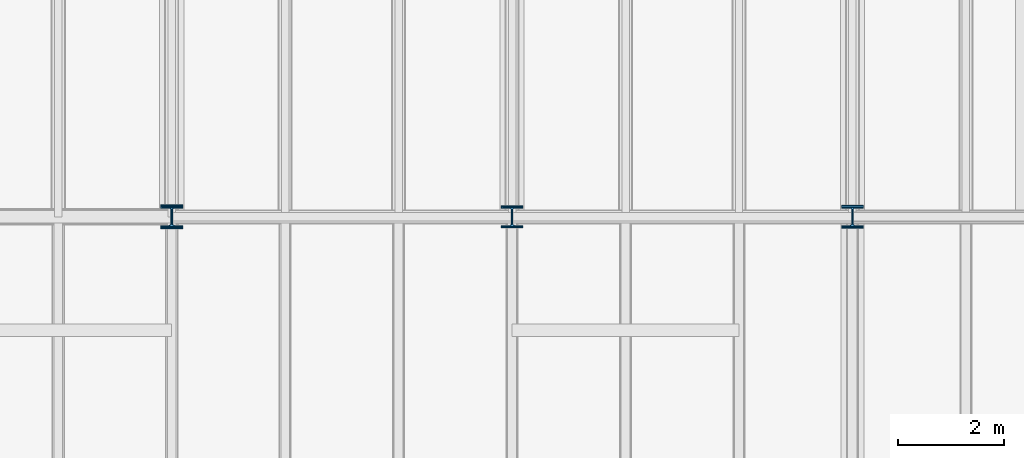
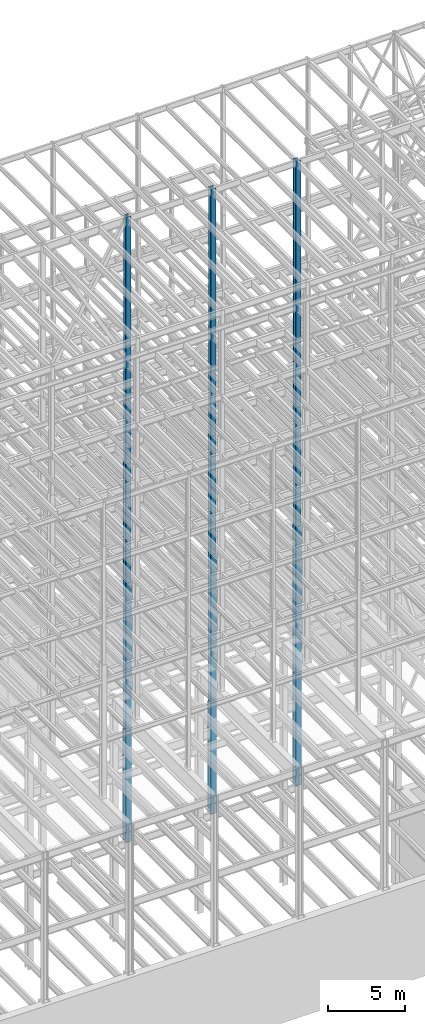
# One storey, part 35 of 150: 15 columns.
"""IFC2X3 building model written with IfcOpenShell, lengths in millimetres."""

from ifc_helpers import new_model, si_unit, frame, origin_with_axes, origin_2d_with_axis, place, context, subcontext, project, spatial, i_section, extrude, material, type_object, element, save


model = new_model("IFC2X3")

# Units and contexts
model_context = context("Model", 3, precision=1e-05, world=origin_with_axes())
body_context = subcontext(model_context, "Body", "Model", "MODEL_VIEW")
ifc_project = project(units=[si_unit("LENGTHUNIT", "METRE", prefix="MILLI"), si_unit("AREAUNIT", "SQUARE_METRE"), si_unit("VOLUMEUNIT", "CUBIC_METRE"), si_unit("MASSUNIT", "GRAM", prefix="KILO"), si_unit("TIMEUNIT", "SECOND"), si_unit("PLANEANGLEUNIT", "RADIAN"), si_unit("SOLIDANGLEUNIT", "STERADIAN"), si_unit("THERMODYNAMICTEMPERATUREUNIT", "DEGREE_CELSIUS"), si_unit("LUMINOUSINTENSITYUNIT", "LUMEN")], contexts=[model_context])

# Site, building, storey
site_placement = place(None, origin_with_axes())
site = spatial("IfcSite", under=ifc_project, at=site_placement, CompositionType="ELEMENT")
building_placement = place(site_placement, origin_with_axes())
building = spatial("IfcBuilding", under=site, at=building_placement, Name="Undefined", CompositionType="ELEMENT")
storey_placement = place(building_placement, origin_with_axes())
storey = spatial("IfcBuildingStorey", under=building, at=storey_placement, Name="Undefined", CompositionType="ELEMENT", Elevation=0.0)

# Columns
ifc_material = material(Name="STEEL/A992")
column_type_1 = type_object("IfcColumnType", Name="W14X311", PredefinedType="NOTDEFINED")
column_1_placement = place(storey_placement, frame((43789.6, 22479.0, 16154.4), z_axis=(0.0, 0.0, 1.0), x_axis=(1.0, 0.0, 0.0)))
element("IfcColumn", 1, at=column_1_placement, inside=storey, type_object=column_type_1, material=ifc_material, Name="COLUMN", ObjectType="W14X311", context=body_context, shape_type="SweptSolid", body=[
    extrude(i_section(OverallWidth=412.75, OverallDepth=434.975, WebThickness=36.5125, FlangeThickness=57.404, FilletRadius=33.0834, at=origin_2d_with_axis()), frame((0.0, 0.0, 8839.2), z_axis=(0.0, 0.0, -1.0), x_axis=(-1.0, 0.0, 0.0)), (0.0, 0.0, 1.0), 8839.2),
])
column_type_2 = type_object("IfcColumnType", Name="W14X90", PredefinedType="NOTDEFINED")
column_2_placement = place(storey_placement, frame((43789.6, 22479.0, 55702.2), z_axis=(0.0, 0.0, 1.0), x_axis=(1.0, 0.0, 0.0)))
element("IfcColumn", 2, at=column_2_placement, inside=storey, type_object=column_type_2, material=ifc_material, Name="COLUMN", ObjectType="W14X90", context=body_context, shape_type="SweptSolid", body=[
    extrude(i_section(OverallWidth=368.3, OverallDepth=355.6, WebThickness=11.1125, FlangeThickness=18.034, FilletRadius=32.7659, at=origin_2d_with_axis()), frame((0.0, 0.0, 10210.8), z_axis=(0.0, 0.0, -1.0), x_axis=(-1.0, 0.0, 0.0)), (0.0, 0.0, 1.0), 10210.8),
])
column_3_placement = place(storey_placement, frame((43789.6, 22479.0, 46253.4), z_axis=(0.0, 0.0, 1.0), x_axis=(1.0, 0.0, 0.0)))
element("IfcColumn", 3, at=column_3_placement, inside=storey, type_object=column_type_2, material=ifc_material, Name="COLUMN", ObjectType="W14X90", context=body_context, shape_type="SweptSolid", body=[
    extrude(i_section(OverallWidth=368.3, OverallDepth=355.6, WebThickness=11.1125, FlangeThickness=18.034, FilletRadius=32.7659, at=origin_2d_with_axis()), frame((0.0, 0.0, 9448.8), z_axis=(0.0, 0.0, -1.0), x_axis=(-1.0, 0.0, 0.0)), (0.0, 0.0, 1.0), 9448.8),
])
column_4_placement = place(storey_placement, frame((37388.8, 22479.0, 55702.2), z_axis=(0.0, 0.0, 1.0), x_axis=(1.0, 0.0, 0.0)))
element("IfcColumn", 4, at=column_4_placement, inside=storey, type_object=column_type_2, material=ifc_material, Name="COLUMN", ObjectType="W14X90", context=body_context, shape_type="SweptSolid", body=[
    extrude(i_section(OverallWidth=368.3, OverallDepth=355.6, WebThickness=11.1125, FlangeThickness=18.034, FilletRadius=32.7659, at=origin_2d_with_axis()), frame((0.0, 0.0, 10210.8), z_axis=(0.0, 0.0, -1.0), x_axis=(-1.0, 0.0, 0.0)), (0.0, 0.0, 1.0), 10210.8),
])
column_5_placement = place(storey_placement, frame((37388.8, 22479.0, 46253.4), z_axis=(0.0, 0.0, 1.0), x_axis=(1.0, 0.0, 0.0)))
element("IfcColumn", 5, at=column_5_placement, inside=storey, type_object=column_type_2, material=ifc_material, Name="COLUMN", ObjectType="W14X90", context=body_context, shape_type="SweptSolid", body=[
    extrude(i_section(OverallWidth=368.3, OverallDepth=355.6, WebThickness=11.1125, FlangeThickness=18.034, FilletRadius=32.7659, at=origin_2d_with_axis()), frame((0.0, 0.0, 9448.8), z_axis=(0.0, 0.0, -1.0), x_axis=(-1.0, 0.0, 0.0)), (0.0, 0.0, 1.0), 9448.8),
])
column_6_placement = place(storey_placement, frame((30988.0, 22479.0, 55702.2), z_axis=(0.0, 0.0, 1.0), x_axis=(1.0, 0.0, 0.0)))
element("IfcColumn", 6, at=column_6_placement, inside=storey, type_object=column_type_2, material=ifc_material, Name="COLUMN", ObjectType="W14X90", context=body_context, shape_type="SweptSolid", body=[
    extrude(i_section(OverallWidth=368.3, OverallDepth=355.6, WebThickness=11.1125, FlangeThickness=18.034, FilletRadius=32.7659, at=origin_2d_with_axis()), frame((0.0, 0.0, 10210.8), z_axis=(0.0, 0.0, -1.0), x_axis=(-1.0, 0.0, 0.0)), (0.0, 0.0, 1.0), 10210.8),
])
column_7_placement = place(storey_placement, frame((30988.0, 22479.0, 46253.4), z_axis=(0.0, 0.0, 1.0), x_axis=(1.0, 0.0, 0.0)))
element("IfcColumn", 7, at=column_7_placement, inside=storey, type_object=column_type_2, material=ifc_material, Name="COLUMN", ObjectType="W14X90", context=body_context, shape_type="SweptSolid", body=[
    extrude(i_section(OverallWidth=368.3, OverallDepth=355.6, WebThickness=11.1125, FlangeThickness=18.034, FilletRadius=32.7659, at=origin_2d_with_axis()), frame((0.0, 0.0, 9448.8), z_axis=(0.0, 0.0, -1.0), x_axis=(-1.0, 0.0, 0.0)), (0.0, 0.0, 1.0), 9448.8),
])
column_type_3 = type_object("IfcColumnType", Name="W14X257", PredefinedType="NOTDEFINED")
for number, where, z_axis, x_axis, name in (
    (8, (43789.6, 22479.0, 24993.6), (0.0, 0.0, 1.0), (1.0, 0.0, 0.0), "COLUMN"),
    (9, (37388.8, 22479.0, 24993.6), (0.0, 0.0, 1.0), (1.0, 0.0, 0.0), "COLUMN"),
):
    element("IfcColumn", number, at=place(storey_placement, frame(where, z_axis=z_axis, x_axis=x_axis)), inside=storey, type_object=column_type_3, material=ifc_material, Name=name, ObjectType="W14X257", context=body_context, shape_type="SweptSolid", body=[
        extrude(i_section(OverallWidth=406.4, OverallDepth=415.925, WebThickness=30.1625, FlangeThickness=48.006, FilletRadius=32.9564, at=origin_2d_with_axis()), frame((0.0, 0.0, 11811.0), z_axis=(0.0, 0.0, -1.0), x_axis=(-1.0, 0.0, 0.0)), (0.0, 0.0, 1.0), 11811.0),
    ])
column_type_4 = type_object("IfcColumnType", Name="W14X145", PredefinedType="NOTDEFINED")
column_8_placement = place(storey_placement, frame((43789.6, 22479.0, 36804.6), z_axis=(0.0, 0.0, 1.0), x_axis=(1.0, 0.0, 0.0)))
element("IfcColumn", 10, at=column_8_placement, inside=storey, type_object=column_type_4, material=ifc_material, Name="COLUMN", ObjectType="W14X145", context=body_context, shape_type="SweptSolid", body=[
    extrude(i_section(OverallWidth=393.7, OverallDepth=374.65, WebThickness=17.4625, FlangeThickness=27.686, FilletRadius=32.6389, at=origin_2d_with_axis()), frame((0.0, 0.0, 9448.8), z_axis=(0.0, 0.0, -1.0), x_axis=(-1.0, 0.0, 0.0)), (0.0, 0.0, 1.0), 9448.8),
])
column_type_5 = type_object("IfcColumnType", Name="W14X159", PredefinedType="NOTDEFINED")
for number, where, z_axis, x_axis, name in (
    (11, (37388.8, 22479.0, 36804.6), (0.0, 0.0, 1.0), (1.0, 0.0, 0.0), "COLUMN"),
    (12, (30988.0, 22479.0, 36804.6), (0.0, 0.0, 1.0), (1.0, 0.0, 0.0), "COLUMN"),
):
    element("IfcColumn", number, at=place(storey_placement, frame(where, z_axis=z_axis, x_axis=x_axis)), inside=storey, type_object=column_type_5, material=ifc_material, Name=name, ObjectType="W14X159", context=body_context, shape_type="SweptSolid", body=[
        extrude(i_section(OverallWidth=396.24, OverallDepth=381.0, WebThickness=19.0499, FlangeThickness=30.226, FilletRadius=33.2739, at=origin_2d_with_axis()), frame((0.0, 0.0, 9448.8), z_axis=(0.0, 0.0, -1.0), x_axis=(-1.0, 0.0, 0.0)), (0.0, 0.0, 1.0), 9448.8),
    ])
column_type_6 = type_object("IfcColumnType", Name="W14X283", PredefinedType="NOTDEFINED")
column_9_placement = place(storey_placement, frame((37388.8, 22479.0, 16154.4), z_axis=(0.0, 0.0, 1.0), x_axis=(1.0, 0.0, 0.0)))
element("IfcColumn", 13, at=column_9_placement, inside=storey, type_object=column_type_6, material=ifc_material, Name="COLUMN", ObjectType="W14X283", context=body_context, shape_type="SweptSolid", body=[
    extrude(i_section(OverallWidth=408.94, OverallDepth=425.45, WebThickness=33.3375, FlangeThickness=52.578, FilletRadius=33.1469, at=origin_2d_with_axis()), frame((0.0, 0.0, 8839.2), z_axis=(0.0, 0.0, -1.0), x_axis=(-1.0, 0.0, 0.0)), (0.0, 0.0, 1.0), 8839.2),
])
column_10_placement = place(storey_placement, frame((30988.0, 22479.0, 24993.6), z_axis=(0.0, 0.0, 1.0), x_axis=(1.0, 0.0, 0.0)))
element("IfcColumn", 14, at=column_10_placement, inside=storey, type_object=column_type_6, material=ifc_material, Name="COLUMN", ObjectType="W14X283", context=body_context, shape_type="SweptSolid", body=[
    extrude(i_section(OverallWidth=408.94, OverallDepth=425.45, WebThickness=33.3375, FlangeThickness=52.578, FilletRadius=33.1469, at=origin_2d_with_axis()), frame((0.0, 0.0, 11811.0), z_axis=(0.0, 0.0, -1.0), x_axis=(-1.0, 0.0, 0.0)), (0.0, 0.0, 1.0), 11811.0),
])
column_type_7 = type_object("IfcColumnType", Name="W14X370", PredefinedType="NOTDEFINED")
column_11_placement = place(storey_placement, frame((30988.0, 22479.0, 16154.4), z_axis=(0.0, 0.0, 1.0), x_axis=(1.0, 0.0, 0.0)))
element("IfcColumn", 15, at=column_11_placement, inside=storey, type_object=column_type_7, material=ifc_material, Name="COLUMN", ObjectType="W14X370", context=body_context, shape_type="SweptSolid", body=[
    extrude(i_section(OverallWidth=419.1, OverallDepth=454.025, WebThickness=42.8625, FlangeThickness=67.564, FilletRadius=32.4484, at=origin_2d_with_axis()), frame((0.0, 0.0, 8839.2), z_axis=(0.0, 0.0, -1.0), x_axis=(-1.0, 0.0, 0.0)), (0.0, 0.0, 1.0), 8839.2),
])

save(model, "model.ifc")
